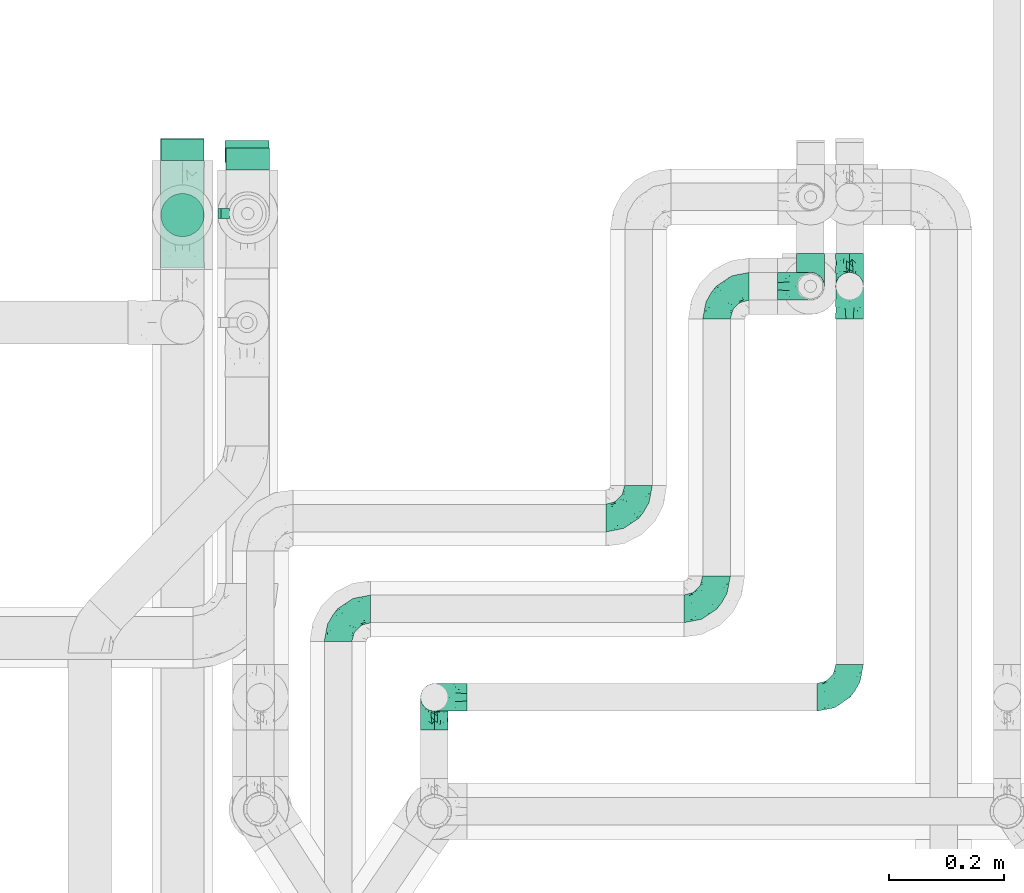
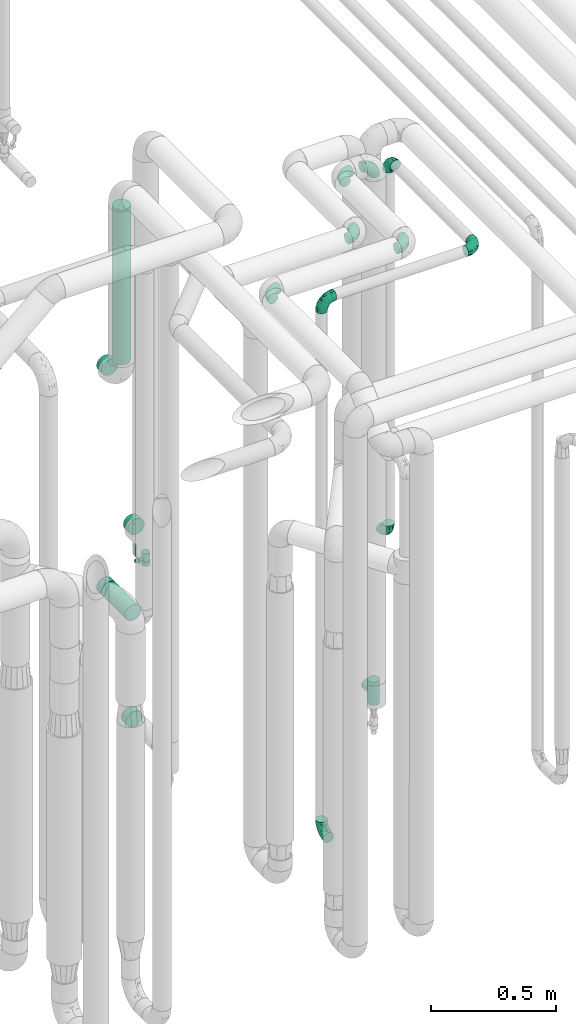
# One storey, part 674 of 827: 15 flow fittings, 2 flow segments, 1 flow controller.
"""IFC2X3 building model written with IfcOpenShell, lengths in millimetres."""

from ifc_helpers import new_model, entity, si_unit, converted_unit, derived_unit, direction, frame, origin, origin_2d_with_axis, place, context, subcontext, project, spatial, polyline, circle, outline, extrude, faceted_brep, source, transform, mapped, material, material_list, type_object, type_shapes, element, save


model = new_model("IFC2X3")

# Units and contexts
model_context = context("Model", 3, precision=0.01, world=origin(), true_north=direction((6.12303176911189e-17, 1.0)))
body_context = subcontext(model_context, "Body", "Model", "MODEL_VIEW")
ifc_project = project(units=[si_unit("LENGTHUNIT", "METRE", prefix="MILLI"), si_unit("AREAUNIT", "SQUARE_METRE"), si_unit("VOLUMEUNIT", "CUBIC_METRE"), converted_unit("PLANEANGLEUNIT", "DEGREE", entity("IfcRatioMeasure", 0.0174532925199433), si_unit("PLANEANGLEUNIT", "RADIAN"), dimensions=[0, 0, 0, 0, 0, 0, 0]), si_unit("MASSUNIT", "GRAM", prefix="KILO"), derived_unit("MASSDENSITYUNIT", [(si_unit("MASSUNIT", "GRAM", prefix="KILO"), 1), (si_unit("LENGTHUNIT", "METRE"), -3)]), derived_unit("MOMENTOFINERTIAUNIT", [(si_unit("LENGTHUNIT", "METRE"), 4)]), si_unit("TIMEUNIT", "SECOND"), si_unit("FREQUENCYUNIT", "HERTZ"), si_unit("THERMODYNAMICTEMPERATUREUNIT", "DEGREE_CELSIUS"), derived_unit("THERMALTRANSMITTANCEUNIT", [(si_unit("MASSUNIT", "GRAM", prefix="KILO"), 1), (si_unit("THERMODYNAMICTEMPERATUREUNIT", "KELVIN"), -1), (si_unit("TIMEUNIT", "SECOND"), -3)]), derived_unit("VOLUMETRICFLOWRATEUNIT", [(si_unit("LENGTHUNIT", "METRE"), 3), (si_unit("TIMEUNIT", "SECOND"), -1)]), derived_unit("MASSFLOWRATEUNIT", [(si_unit("MASSUNIT", "GRAM", prefix="KILO"), 1), (si_unit("TIMEUNIT", "SECOND"), -1)]), derived_unit("ROTATIONALFREQUENCYUNIT", [(si_unit("TIMEUNIT", "SECOND"), -1)]), si_unit("ELECTRICCURRENTUNIT", "AMPERE"), si_unit("ELECTRICVOLTAGEUNIT", "VOLT"), si_unit("POWERUNIT", "WATT"), si_unit("FORCEUNIT", "NEWTON", prefix="KILO"), si_unit("ILLUMINANCEUNIT", "LUX"), si_unit("LUMINOUSFLUXUNIT", "LUMEN"), si_unit("LUMINOUSINTENSITYUNIT", "CANDELA"), derived_unit("USERDEFINED", [(si_unit("MASSUNIT", "GRAM", prefix="KILO"), -1), (si_unit("LENGTHUNIT", "METRE"), -2), (si_unit("TIMEUNIT", "SECOND"), 3), (si_unit("LUMINOUSFLUXUNIT", "LUMEN"), 1)]), derived_unit("LINEARVELOCITYUNIT", [(si_unit("LENGTHUNIT", "METRE"), 1), (si_unit("TIMEUNIT", "SECOND"), -1)]), si_unit("PRESSUREUNIT", "PASCAL"), derived_unit("USERDEFINED", [(si_unit("LENGTHUNIT", "METRE"), -2), (si_unit("MASSUNIT", "GRAM", prefix="KILO"), 1), (si_unit("TIMEUNIT", "SECOND"), -2)]), derived_unit("LINEARFORCEUNIT", [(si_unit("MASSUNIT", "GRAM", prefix="KILO"), 1), (si_unit("LENGTHUNIT", "METRE"), 1), (si_unit("TIMEUNIT", "SECOND"), -2), (si_unit("LENGTHUNIT", "METRE"), -1)]), derived_unit("PLANARFORCEUNIT", [(si_unit("MASSUNIT", "GRAM", prefix="KILO"), 1), (si_unit("LENGTHUNIT", "METRE"), 1), (si_unit("TIMEUNIT", "SECOND"), -2), (si_unit("LENGTHUNIT", "METRE"), -2)])], contexts=[model_context])

# Site, building, storey
site_placement = place(None, origin())
site = spatial("IfcSite", under=ifc_project, at=site_placement, CompositionType="ELEMENT")
building_placement = place(site_placement, origin())
building = spatial("IfcBuilding", under=site, at=building_placement, CompositionType="ELEMENT")
storey_placement = place(building_placement, frame((0.0, 0.0, 28200.0)))
storey = spatial("IfcBuildingStorey", under=building, at=storey_placement, Name="08", CompositionType="ELEMENT", Elevation=28200.0)

# Flow segments
pipe_segment_type = type_object("IfcPipeSegmentType", PredefinedType="NOTDEFINED")
flow_segment_1_placement = place(storey_placement, frame((46517.3, 15183.04, 1125.65)))
element("IfcFlowSegment", 1, at=flow_segment_1_placement, inside=storey, type_object=pipe_segment_type, context=body_context, shape_type="SweptSolid", body=[
    extrude(circle(Radius=37.75, at=origin_2d_with_axis()), frame((39.35, 0.0, 39.35), z_axis=(0.0, 1.0, 0.0), x_axis=(1.0, 0.0, 0.0)), (0.0, 0.0, 1.0), 188.200000000003),
])
flow_segment_2_placement = place(storey_placement, frame((46517.43, 15236.02, 2345.05)))
element("IfcFlowSegment", 2, at=flow_segment_2_placement, inside=storey, type_object=pipe_segment_type, context=body_context, shape_type="SweptSolid", body=[
    extrude(circle(Radius=37.75, at=origin_2d_with_axis()), frame((39.35, 39.35, 0.0)), (0.0, 0.0, 1.0), 760.000000000018),
])

# Flow controller
ifc_material = material()
ifc_material_list = material_list([ifc_material, ifc_material, ifc_material, ifc_material, ifc_material])
valve_type = type_object("IfcValveType", PredefinedType="NOTDEFINED", material=ifc_material_list)
shared_shape_1 = source(origin(), body_context, "Body", "SweptSolid", [
    extrude(circle(Radius=17.5, at=origin_2d_with_axis()), frame((-30.5, 0.0, 0.0), z_axis=(1.0, 0.0, 0.0), x_axis=(0.0, 1.0, 0.0)), (0.0, 0.0, 1.0), 20.3333333333333),
    extrude(circle(Radius=16.0, at=origin_2d_with_axis()), frame((-10.17, 0.0, 0.0), z_axis=(1.0, 0.0, 0.0), x_axis=(0.0, 1.0, 0.0)), (0.0, 0.0, 1.0), 20.3333333333333),
    extrude(circle(Radius=17.5, at=origin_2d_with_axis()), frame((10.17, 0.0, 0.0), z_axis=(1.0, 0.0, 0.0), x_axis=(0.0, 1.0, 0.0)), (0.0, 0.0, 1.0), 20.3333333333333),
    extrude(outline(polyline([(-38.75, -5.0), (-38.75, -10.0), (-17.92, -10.0), (2.08, 5.0), (56.25, 5.0), (56.25, 10.0), (0.42, 10.0), (-19.58, -5.0), (-38.75, -5.0)])), frame((28.75, -8.75, 41.5), z_axis=(0.0, -1.0, 0.0), x_axis=(1.0, 0.0, 0.0)), (0.0, 0.0, -1.0), 17.5),
    extrude(circle(Radius=8.0, at=origin_2d_with_axis()), origin(), (0.0, 0.0, 1.0), 49.0),
])
type_shapes(valve_type, [shared_shape_1])
flow_controller_placement = place(storey_placement, frame((46670.56, 15278.08, 1335.75), z_axis=(-1.0, 0.0, 0.0), x_axis=(0.0, 0.0, 1.0)))
element("IfcFlowController", 3, at=flow_controller_placement, inside=storey, type_object=valve_type, material=ifc_material, context=body_context, shape_type="MappedRepresentation", body=[
    mapped(shared_shape_1, transform((0.0, 0.0, 0.0), scale=1.0)),
])

# Flow fittings
pipe_fitting_type_1 = type_object("IfcPipeFittingType", Name="ADSK_1", PredefinedType="NOTDEFINED", material=ifc_material)
shared_shape_2 = source(origin(), body_context, "Body", "SweptSolid", [
    extrude(circle(Radius=38.05, at=origin_2d_with_axis()), frame((0.0, 0.0, 0.0), z_axis=(1.0, 0.0, 0.0), x_axis=(0.0, 1.0, 0.0)), (0.0, 0.0, 1.0), 38.0000000000003),
])
type_shapes(pipe_fitting_type_1, [shared_shape_2])
for number, where, z_axis, x_axis, name in (
    (4, (46556.77, 15370.36, 2250.05), (1.0, 0.0, 0.0), (0.0, 1.0, 0.0), "ADSK_1"),
    (5, (46670.56, 15354.08, 1442.25), (-1.0, 0.0, 0.0), (0.0, 1.0, 0.0), "ADSK_1"),
    (6, (46556.64, 15371.24, 1165.0), (0.0, 0.0, 1.0), (0.0, 1.0, 0.0), "ADSK_1"),
    (7, (46669.38, 15367.24, 494.0), (0.0, 0.0, 1.0), (0.0, 1.0, 0.0), "ADSK_1"),
):
    element("IfcFlowFitting", number, at=place(storey_placement, frame(where, z_axis=z_axis, x_axis=x_axis)), inside=storey, type_object=pipe_fitting_type_1, material=ifc_material, Name=name, ObjectType="ADSK_1", context=body_context, shape_type="MappedRepresentation", body=[
        mapped(shared_shape_2, transform((0.0, 0.0, 0.0), scale=1.0)),
    ])
pipe_fitting_type_2 = type_object("IfcPipeFittingType", Name="ADSK_1", PredefinedType="NOTDEFINED", material=ifc_material)
shared_shape_3 = source(origin(), body_context, "Body", "Brep", [
    faceted_brep([(-57.0, 12.07, -20.91), (-57.0, 6.25, -23.33), (-57.0, 0.0, -24.15), (-57.0, -6.25, -23.33), (-57.0, -12.08, -20.91), (-57.0, -17.08, -17.08), (-57.0, -20.91, -12.08), (-57.0, -23.33, -6.25), (-57.0, -24.15, 0.0), (-57.0, -23.33, 6.25), (-57.0, -20.91, 12.07), (-57.0, -17.08, 17.08), (-57.0, -12.08, 20.91), (-57.0, -6.25, 23.33), (-57.0, 0.0, 24.15), (-57.0, 6.25, 23.33), (-57.0, 12.07, 20.91), (-57.0, 17.08, 17.08), (-57.0, 20.91, 12.07), (-57.0, 23.33, 6.25), (-57.0, 24.15, 0.0), (-57.0, 23.33, -6.25), (-57.0, 20.91, -12.08), (-57.0, 17.08, -17.08), (0.0, 57.0, -24.15), (-6.25, 57.0, -23.33), (-12.07, 57.0, -20.91), (-17.08, 57.0, -17.08), (-20.91, 57.0, -12.08), (-23.33, 57.0, -6.25), (-24.15, 57.0, 0.0), (-23.33, 57.0, 6.25), (-20.91, 57.0, 12.07), (-17.08, 57.0, 17.08), (-12.07, 57.0, 20.91), (-6.25, 57.0, 23.33), (0.0, 57.0, 24.15), (6.25, 57.0, 23.33), (12.08, 57.0, 20.91), (17.08, 57.0, 17.08), (20.91, 57.0, 12.07), (23.33, 57.0, 6.25), (24.15, 57.0, 0.0), (23.33, 57.0, -6.25), (20.91, 57.0, -12.08), (17.08, 57.0, -17.08), (12.08, 57.0, -20.91), (6.25, 57.0, -23.33), (14.9, 21.14, 6.17), (13.61, 24.64, 12.48), (6.23, 8.95, 8.98), (-41.47, -21.06, 0.0), (-41.92, -18.38, 13.72), (-24.64, -13.61, 12.48), (-37.37, -13.24, 18.15), (-6.8, -4.93, 8.18), (-21.76, -15.19, 6.22), (-12.78, -9.18, 0.0), (-37.73, -20.51, 7.75), (-7.38, 7.38, 20.24), (-23.37, -4.26, 20.42), (-11.9, -3.19, 15.86), (-42.14, -8.7, 21.82), (13.24, 37.37, 18.15), (9.33, 23.53, 16.85), (4.26, 23.37, 20.42), (2.77, 10.92, 15.55), (-29.46, 0.91, 23.52), (-44.13, 20.56, 15.69), (-39.25, 26.33, 10.88), (-49.02, 22.92, 9.96), (-34.58, 23.87, 17.15), (-15.8, 6.8, 22.81), (-8.67, 20.47, 23.88), (-18.12, 12.9, 24.08), (-48.29, 14.92, 19.65), (-44.06, -2.85, 23.78), (-9.23, 48.95, 22.58), (-3.78, 42.74, 24.07), (-40.34, 4.26, 24.09), (-44.02, 26.14, 5.46), (-44.04, 9.88, 22.74), (-4.95, 16.87, 22.52), (-2.75, 1.43, 12.5), (-25.48, 40.98, 10.71), (20.51, 37.73, 7.75), (18.38, 41.92, 13.72), (8.7, 42.14, 21.82), (-25.95, -17.97, 0.0), (2.85, 44.06, 23.78), (21.06, 41.47, 0.0), (17.97, 25.95, 0.0), (-24.04, -9.27, 17.13), (-33.26, 33.26, 5.86), (-28.55, 40.57, 0.0), (-40.57, 28.55, 0.0), (-25.29, 47.19, 4.06), (-27.01, 31.1, 16.77), (-15.7, 43.95, 19.9), (-20.27, 45.22, 15.61), (-30.53, 31.98, 12.64), (-11.28, 38.33, 22.92), (-9.97, 27.88, 24.09), (-20.15, 30.26, 21.25), (-31.25, 11.75, 23.64), (-28.75, 7.23, 24.15), (-29.53, 18.06, 22.27), (-28.44, 24.21, 20.02), (-37.55, 17.7, 20.26), (-15.88, 29.25, 22.99), (-20.82, 20.82, 23.44), (-0.91, 29.46, 23.52), (-13.5, -7.67, 12.04), (1.49, 1.56, 5.16), (8.86, 10.35, 4.59), (0.38, -0.38, 0.0), (9.18, 12.78, 0.0), (-37.37, -13.24, -18.15), (8.86, 10.35, -4.59), (-45.22, 20.27, -15.61), (-43.95, 15.7, -19.9), (-38.33, 11.28, -22.92), (-48.95, 9.23, -22.58), (-47.19, 25.29, -4.06), (-33.26, 33.26, -5.86), (18.38, 41.92, -13.72), (-30.26, 20.15, -21.25), (2.85, 44.06, -23.78), (-4.26, 40.34, -24.09), (-40.98, 25.48, -10.71), (-41.92, -18.38, -13.72), (9.25, 23.5, -16.92), (4.26, 23.37, -20.42), (13.24, 37.37, -18.15), (-37.73, -20.51, -7.75), (-11.75, 31.25, -23.64), (-7.23, 28.75, -24.15), (-12.9, 18.12, -24.08), (8.7, 42.14, -21.82), (-44.06, -2.85, -23.78), (-6.8, 15.8, -22.81), (-20.47, 8.67, -23.88), (-24.64, -13.61, -12.48), (-42.74, 3.78, -24.07), (-18.06, 29.53, -22.27), (-24.21, 28.44, -20.02), (-27.88, 9.97, -24.09), (-31.1, 27.01, -16.77), (-26.14, 44.02, -5.46), (14.9, 21.14, -6.17), (20.51, 37.73, -7.75), (-9.88, 44.04, -22.74), (-20.56, 44.13, -15.69), (-21.76, -15.19, -6.22), (-13.5, -7.67, -12.04), (-24.14, -9.76, -16.74), (-11.9, -3.19, -15.86), (-14.92, 48.29, -19.65), (-23.37, -4.26, -20.42), (-0.91, 29.46, -23.52), (-26.33, 39.25, -10.88), (-23.87, 34.58, -17.15), (-42.14, -8.7, -21.82), (-22.92, 49.02, -9.96), (13.61, 24.64, -12.48), (-31.98, 30.53, -12.64), (-16.87, 4.95, -22.52), (-17.7, 37.55, -20.26), (-29.25, 15.88, -22.99), (-20.82, 20.82, -23.44), (-29.46, 0.91, -23.52), (-7.38, 7.38, -20.24), (2.77, 10.92, -15.55), (6.23, 8.95, -8.98), (-6.8, -4.93, -8.18), (-2.81, 1.41, -12.54), (1.49, 1.56, -5.16)], [[[0, 1, 2, 3, 4, 5, 6, 7, 8, 9, 10, 11, 12, 13, 14, 15, 16, 17, 18, 19, 20, 21, 22, 23]], [[24, 25, 26, 27, 28, 29, 30, 31, 32, 33, 34, 35, 36, 37, 38, 39, 40, 41, 42, 43, 44, 45, 46, 47]], [[48, 49, 50]], [[9, 8, 51]], [[52, 53, 54]], [[55, 56, 57]], [[10, 58, 52]], [[9, 58, 10]], [[59, 60, 61]], [[54, 12, 11]], [[54, 62, 12]], [[63, 39, 38]], [[64, 65, 66]], [[62, 60, 67]], [[68, 69, 70]], [[71, 69, 68]], [[72, 73, 74]], [[16, 75, 17]], [[13, 76, 14]], [[35, 77, 78]], [[14, 79, 15]], [[17, 68, 18]], [[14, 76, 79]], [[20, 19, 80]], [[70, 19, 18]], [[81, 15, 79]], [[15, 81, 16]], [[73, 72, 82]], [[66, 83, 50]], [[32, 31, 84]], [[85, 86, 49]], [[63, 87, 65]], [[56, 58, 88]], [[36, 89, 37]], [[85, 41, 40]], [[36, 35, 78]], [[90, 41, 85]], [[40, 39, 86]], [[12, 62, 13]], [[86, 85, 40]], [[48, 85, 49]], [[85, 91, 90]], [[87, 38, 37]], [[92, 60, 54]], [[80, 69, 93]], [[93, 94, 95]], [[10, 52, 11]], [[94, 96, 30]], [[97, 98, 99]], [[80, 93, 95]], [[100, 97, 84]], [[99, 98, 33]], [[101, 102, 78]], [[103, 101, 98]], [[96, 31, 30]], [[77, 98, 101]], [[77, 35, 34]], [[34, 33, 98]], [[9, 51, 58]], [[87, 63, 38]], [[104, 105, 74]], [[106, 103, 107]], [[106, 81, 104]], [[75, 68, 17]], [[108, 107, 71]], [[33, 32, 99]], [[109, 103, 110]], [[101, 109, 102]], [[89, 78, 111]], [[53, 52, 58]], [[54, 11, 52]], [[60, 62, 54]], [[88, 58, 51]], [[76, 62, 67]], [[53, 112, 92]], [[60, 59, 72]], [[39, 63, 86]], [[49, 86, 63]], [[89, 87, 37]], [[42, 41, 90]], [[111, 82, 65]], [[111, 65, 87]], [[65, 59, 66]], [[104, 81, 79]], [[75, 81, 108]], [[32, 84, 99]], [[97, 99, 84]], [[98, 97, 103]], [[106, 107, 108]], [[74, 102, 110]], [[111, 78, 102]], [[74, 110, 104]], [[74, 67, 72]], [[61, 92, 112]], [[66, 59, 61]], [[56, 53, 58]], [[66, 50, 49]], [[61, 112, 83]], [[66, 49, 64]], [[78, 89, 36]], [[87, 89, 111]], [[62, 76, 13]], [[79, 76, 67]], [[100, 93, 69]], [[96, 93, 84]], [[55, 113, 50]], [[113, 114, 50]], [[104, 79, 105]], [[106, 104, 110]], [[20, 80, 95]], [[85, 48, 91]], [[115, 114, 113]], [[116, 91, 48]], [[70, 80, 19]], [[93, 96, 94]], [[84, 31, 96]], [[103, 106, 110]], [[81, 106, 108]], [[103, 97, 107]], [[71, 107, 97]], [[71, 97, 100]], [[108, 71, 68]], [[79, 67, 105]], [[67, 74, 105]], [[115, 113, 57]], [[112, 56, 55]], [[56, 88, 57]], [[60, 72, 67]], [[82, 72, 59]], [[65, 82, 59]], [[82, 111, 73]], [[111, 102, 73]], [[102, 74, 73]], [[81, 75, 16]], [[68, 75, 108]], [[68, 70, 18]], [[80, 70, 69]], [[98, 77, 34]], [[78, 77, 101]], [[93, 100, 84]], [[71, 100, 69]], [[102, 109, 110]], [[101, 103, 109]], [[53, 92, 54]], [[61, 60, 92]], [[56, 112, 53]], [[83, 112, 55]], [[50, 83, 55]], [[61, 83, 66]], [[49, 63, 64]], [[65, 64, 63]], [[57, 113, 55]], [[114, 115, 116]], [[116, 48, 114]], [[48, 50, 114]], [[117, 5, 4]], [[116, 115, 118]], [[119, 120, 23]], [[121, 122, 120]], [[95, 123, 20]], [[0, 23, 120]], [[124, 95, 94]], [[125, 45, 44]], [[121, 120, 126]], [[24, 127, 128]], [[22, 21, 129]], [[0, 122, 1]], [[5, 117, 130]], [[131, 132, 133]], [[134, 88, 51]], [[135, 136, 137]], [[6, 5, 130]], [[46, 138, 47]], [[139, 3, 2]], [[140, 141, 137]], [[6, 134, 7]], [[134, 130, 142]], [[143, 2, 1]], [[144, 126, 145]], [[121, 146, 143]], [[147, 120, 119]], [[94, 148, 124]], [[149, 150, 91]], [[30, 29, 148]], [[151, 25, 128]], [[27, 152, 28]], [[134, 153, 88]], [[154, 155, 156]], [[27, 26, 157]], [[151, 26, 25]], [[155, 158, 156]], [[24, 47, 127]], [[1, 122, 143]], [[138, 132, 159]], [[160, 152, 161]], [[24, 128, 25]], [[46, 133, 138]], [[162, 117, 4]], [[148, 160, 124]], [[152, 160, 163]], [[154, 142, 155]], [[45, 125, 133]], [[133, 46, 45]], [[125, 164, 133]], [[51, 7, 134]], [[42, 90, 43]], [[165, 147, 129]], [[153, 134, 142]], [[43, 150, 44]], [[162, 4, 3]], [[141, 140, 166]], [[117, 162, 158]], [[163, 29, 28]], [[43, 90, 150]], [[123, 21, 20]], [[144, 151, 135]], [[157, 152, 27]], [[167, 145, 161]], [[23, 22, 119]], [[168, 126, 169]], [[121, 168, 146]], [[139, 143, 170]], [[142, 130, 117]], [[8, 7, 51]], [[134, 6, 130]], [[139, 162, 3]], [[170, 166, 158]], [[170, 158, 162]], [[158, 171, 156]], [[44, 150, 125]], [[91, 150, 90]], [[164, 125, 150]], [[132, 138, 133]], [[127, 138, 159]], [[131, 164, 172]], [[132, 171, 140]], [[135, 151, 128]], [[157, 151, 167]], [[22, 129, 119]], [[147, 119, 129]], [[120, 147, 126]], [[144, 145, 167]], [[137, 146, 169]], [[170, 143, 146]], [[137, 169, 135]], [[137, 159, 140]], [[171, 172, 156]], [[173, 174, 175]], [[156, 175, 154]], [[174, 57, 153]], [[132, 172, 171]], [[172, 164, 173]], [[143, 139, 2]], [[162, 139, 170]], [[138, 127, 47]], [[128, 127, 159]], [[165, 124, 160]], [[123, 124, 129]], [[149, 173, 164]], [[176, 174, 173]], [[135, 128, 136]], [[144, 135, 169]], [[150, 149, 164]], [[176, 118, 115]], [[149, 91, 116]], [[30, 148, 94]], [[163, 148, 29]], [[124, 123, 95]], [[129, 21, 123]], [[126, 144, 169]], [[151, 144, 167]], [[126, 147, 145]], [[161, 145, 147]], [[161, 147, 165]], [[167, 161, 152]], [[128, 159, 136]], [[159, 137, 136]], [[154, 153, 142]], [[132, 140, 159]], [[174, 176, 57]], [[57, 88, 153]], [[166, 140, 171]], [[158, 166, 171]], [[166, 170, 141]], [[170, 146, 141]], [[146, 137, 141]], [[151, 157, 26]], [[152, 157, 167]], [[152, 163, 28]], [[148, 163, 160]], [[120, 122, 0]], [[143, 122, 121]], [[124, 165, 129]], [[161, 165, 160]], [[146, 168, 169]], [[121, 126, 168]], [[142, 117, 155]], [[158, 155, 117]], [[175, 156, 172]], [[153, 154, 174]], [[173, 175, 172]], [[174, 154, 175]], [[164, 131, 133]], [[172, 132, 131]], [[176, 173, 118]], [[57, 176, 115]], [[173, 149, 118]], [[149, 116, 118]]]),
])
type_shapes(pipe_fitting_type_2, [shared_shape_3])
for number, where, z_axis, x_axis, name in (
    (8, (46996.03, 14434.53, 400.0), (-1.0, 0.0, 0.0), (0.0, 0.0, -1.0), "ADSK_1"),
    (9, (47720.02, 15151.24, 3000.0), (-1.0, 0.0, 0.0), (0.0, 1.0, 0.0), "ADSK_1"),
    (10, (47720.02, 15151.24, 1160.0), (1.0, 0.0, 0.0), (0.0, 0.0, -1.0), "ADSK_1"),
    (11, (47488.0, 15151.24, 3000.0), (0.0, 0.0, 1.0), (-1.0, 0.0, 0.0), "ADSK_1"),
    (12, (47651.75, 15151.24, 3000.0), (0.0, 1.0, 0.0), (1.0, 0.0, 0.0), "ADSK_1"),
):
    element("IfcFlowFitting", number, at=place(storey_placement, frame(where, z_axis=z_axis, x_axis=x_axis)), inside=storey, type_object=pipe_fitting_type_2, material=ifc_material, Name=name, ObjectType="ADSK_1", context=body_context, shape_type="MappedRepresentation", body=[
        mapped(shared_shape_3, transform((0.0, 0.0, 0.0), scale=1.0)),
    ])
flow_fitting_1_placement = place(storey_placement, frame((47720.02, 14434.53, 3000.0)))
element("IfcFlowFitting", 13, at=flow_fitting_1_placement, inside=storey, type_object=pipe_fitting_type_2, material=ifc_material, Name="ADSK_1", ObjectType="ADSK_1", context=body_context, shape_type="MappedRepresentation", body=[
    mapped(shared_shape_3, transform((0.0, 0.0, 0.0), scale=1.0)),
])
flow_fitting_2_placement = place(storey_placement, frame((46996.03, 14434.53, 3000.0), z_axis=(0.0, 1.0, 0.0), x_axis=(0.0, 0.0, 1.0)))
element("IfcFlowFitting", 14, at=flow_fitting_2_placement, inside=storey, type_object=pipe_fitting_type_2, material=ifc_material, Name="ADSK_1", ObjectType="ADSK_1", context=body_context, shape_type="MappedRepresentation", body=[
    mapped(shared_shape_3, transform((0.0, 0.0, 0.0), scale=1.0)),
])
flow_fitting_3_placement = place(storey_placement, frame((47488.0, 14588.75, 3000.0)))
element("IfcFlowFitting", 15, at=flow_fitting_3_placement, inside=storey, type_object=pipe_fitting_type_2, material=ifc_material, Name="ADSK_1", ObjectType="ADSK_1", context=body_context, shape_type="MappedRepresentation", body=[
    mapped(shared_shape_3, transform((0.0, 0.0, 0.0), scale=1.0)),
])
flow_fitting_4_placement = place(storey_placement, frame((46828.0, 14588.75, 3000.0), z_axis=(0.0, 0.0, 1.0), x_axis=(-1.0, 0.0, 0.0)))
element("IfcFlowFitting", 16, at=flow_fitting_4_placement, inside=storey, type_object=pipe_fitting_type_2, material=ifc_material, Name="ADSK_1", ObjectType="ADSK_1", context=body_context, shape_type="MappedRepresentation", body=[
    mapped(shared_shape_3, transform((0.0, 0.0, 0.0), scale=1.0)),
])
flow_fitting_5_placement = place(storey_placement, frame((47352.0, 14747.03, 3000.0)))
element("IfcFlowFitting", 17, at=flow_fitting_5_placement, inside=storey, type_object=pipe_fitting_type_2, material=ifc_material, Name="ADSK_1", ObjectType="ADSK_1", context=body_context, shape_type="MappedRepresentation", body=[
    mapped(shared_shape_3, transform((0.0, 0.0, 0.0), scale=1.0)),
])
pipe_fitting_type_3 = type_object("IfcPipeFittingType", Name="ADSK_1", PredefinedType="NOTDEFINED", material=ifc_material)
shared_shape_4 = source(origin(), body_context, "Body", "Brep", [
    faceted_brep([(-57.0, 12.07, -20.91), (-57.0, 6.25, -23.33), (-57.0, 0.0, -24.15), (-57.0, -6.25, -23.33), (-57.0, -12.08, -20.91), (-57.0, -17.08, -17.08), (-57.0, -20.91, -12.08), (-57.0, -23.33, -6.25), (-57.0, -24.15, 0.0), (-57.0, -23.33, 6.25), (-57.0, -20.91, 12.07), (-57.0, -17.08, 17.08), (-57.0, -12.08, 20.91), (-57.0, -6.25, 23.33), (-57.0, 0.0, 24.15), (-57.0, 6.25, 23.33), (-57.0, 12.07, 20.91), (-57.0, 17.08, 17.08), (-57.0, 20.91, 12.07), (-57.0, 23.33, 6.25), (-57.0, 24.15, 0.0), (-57.0, 23.33, -6.25), (-57.0, 20.91, -12.08), (-57.0, 17.08, -17.08), (57.0, 0.0, -24.15), (57.0, 6.25, -23.33), (57.0, 12.07, -20.91), (57.0, 17.08, -17.08), (57.0, 20.91, -12.08), (57.0, 23.33, -6.25), (57.0, 24.15, 0.0), (57.0, 23.33, 6.25), (57.0, 20.91, 12.07), (57.0, 17.08, 17.08), (57.0, 12.07, 20.91), (57.0, 6.25, 23.33), (57.0, 0.0, 24.15), (57.0, -6.25, 23.33), (57.0, -12.08, 20.91), (57.0, -17.08, 17.08), (57.0, -20.91, 12.07), (57.0, -23.33, 6.25), (57.0, -24.15, 0.0), (57.0, -23.33, -6.25), (57.0, -20.91, -12.08), (57.0, -17.08, -17.08), (57.0, -12.08, -20.91), (57.0, -6.25, -23.33), (23.27, -23.27, 6.45), (24.15, -24.15, 0.0), (-24.15, -24.15, 0.0), (20.9, -20.9, 12.1), (13.54, -13.54, 20.0), (17.52, -17.52, 16.62), (-23.27, -23.27, 6.45), (-20.9, -20.9, 12.1), (-17.52, -17.52, 16.62), (-13.54, -13.54, 20.0), (-9.19, -9.19, 22.33), (9.19, -9.19, 22.33), (4.64, -4.64, 23.7), (0.0, 0.0, 24.15), (-4.64, -4.64, 23.7), (4.64, -4.64, -23.7), (0.0, 0.0, -24.15), (-4.64, -4.64, -23.7), (-9.19, -9.19, -22.33), (9.19, -9.19, -22.33), (13.54, -13.54, -20.0), (17.52, -17.52, -16.62), (20.9, -20.9, -12.1), (23.27, -23.27, -6.45), (-13.54, -13.54, -20.0), (-17.52, -17.52, -16.62), (-23.27, -23.27, -6.45), (-20.9, -20.9, -12.1), (0.0, -57.0, -24.15), (6.25, -57.0, -23.33), (12.08, -57.0, -20.91), (17.08, -57.0, -17.08), (20.91, -57.0, -12.08), (23.33, -57.0, -6.25), (24.15, -57.0, 0.0), (23.33, -57.0, 6.25), (20.91, -57.0, 12.07), (17.08, -57.0, 17.08), (12.08, -57.0, 20.91), (6.25, -57.0, 23.33), (0.0, -57.0, 24.15), (-6.25, -57.0, 23.33), (-12.07, -57.0, 20.91), (-17.08, -57.0, 17.08), (-20.91, -57.0, 12.07), (-23.33, -57.0, 6.25), (-24.15, -57.0, 0.0), (-23.33, -57.0, -6.25), (-20.91, -57.0, -12.08), (-17.08, -57.0, -17.08), (-12.07, -57.0, -20.91), (-6.25, -57.0, -23.33)], [[[0, 1, 2, 3, 4, 5, 6, 7, 8, 9, 10, 11, 12, 13, 14, 15, 16, 17, 18, 19, 20, 21, 22, 23]], [[24, 25, 26, 27, 28, 29, 30, 31, 32, 33, 34, 35, 36, 37, 38, 39, 40, 41, 42, 43, 44, 45, 46, 47]], [[41, 40, 48]], [[42, 41, 49]], [[50, 9, 8]], [[49, 41, 48]], [[40, 51, 48]], [[39, 38, 52]], [[51, 40, 53]], [[52, 53, 39]], [[53, 40, 39]], [[50, 54, 9]], [[9, 54, 10]], [[54, 55, 10]], [[56, 57, 11]], [[11, 10, 56]], [[11, 57, 12]], [[56, 10, 55]], [[12, 57, 58]], [[52, 38, 59]], [[60, 36, 61]], [[62, 61, 14]], [[59, 37, 60]], [[37, 59, 38]], [[60, 37, 36]], [[61, 36, 35, 15, 14]], [[32, 31, 19, 18]], [[17, 16, 34, 33]], [[18, 17, 33, 32]], [[35, 34, 16, 15]], [[20, 19, 31, 30]], [[62, 13, 58]], [[13, 62, 14]], [[58, 13, 12]], [[27, 23, 22, 28]], [[22, 21, 29, 28]], [[0, 23, 27, 26]], [[20, 30, 29, 21]], [[24, 47, 63]], [[24, 64, 2, 1, 25]], [[64, 24, 63]], [[2, 64, 65]], [[26, 25, 1, 0]], [[65, 66, 3]], [[2, 65, 3]], [[66, 4, 3]], [[63, 47, 67]], [[46, 45, 68]], [[69, 68, 45]], [[44, 70, 69]], [[69, 45, 44]], [[46, 68, 67]], [[43, 42, 49]], [[7, 50, 8]], [[43, 71, 44]], [[71, 43, 49]], [[44, 71, 70]], [[72, 4, 66]], [[72, 5, 4]], [[5, 72, 73]], [[5, 73, 6]], [[74, 50, 7]], [[75, 74, 6]], [[74, 7, 6]], [[75, 6, 73]], [[46, 67, 47]], [[76, 77, 78, 79, 80, 81, 82, 83, 84, 85, 86, 87, 88, 89, 90, 91, 92, 93, 94, 95, 96, 97, 98, 99]], [[50, 94, 93]], [[54, 50, 93]], [[91, 90, 57]], [[56, 92, 91]], [[54, 93, 92]], [[58, 90, 89]], [[55, 54, 92]], [[56, 55, 92]], [[58, 57, 90]], [[88, 61, 62]], [[58, 89, 62]], [[56, 91, 57]], [[62, 89, 88]], [[60, 88, 87]], [[86, 59, 87]], [[84, 83, 48]], [[53, 85, 84]], [[52, 86, 85]], [[49, 83, 82]], [[59, 60, 87]], [[52, 59, 86]], [[49, 48, 83]], [[51, 53, 84]], [[48, 51, 84]], [[52, 85, 53]], [[88, 60, 61]], [[82, 81, 49]], [[71, 49, 81]], [[69, 80, 79]], [[79, 78, 68]], [[71, 81, 80]], [[67, 78, 77]], [[70, 71, 80]], [[69, 70, 80]], [[67, 68, 78]], [[76, 64, 63]], [[67, 77, 63]], [[69, 79, 68]], [[63, 77, 76]], [[65, 76, 99]], [[98, 66, 99]], [[96, 95, 74]], [[73, 97, 96]], [[72, 98, 97]], [[50, 95, 94]], [[66, 65, 99]], [[72, 66, 98]], [[50, 74, 95]], [[75, 73, 96]], [[74, 75, 96]], [[72, 97, 73]], [[76, 65, 64]]]),
])
type_shapes(pipe_fitting_type_3, [shared_shape_4])
flow_fitting_6_placement = place(storey_placement, frame((47651.75, 15151.24, 420.25), z_axis=(-1.0, 0.0, 0.0), x_axis=(0.0, 0.0, -1.0)))
element("IfcFlowFitting", 18, at=flow_fitting_6_placement, inside=storey, type_object=pipe_fitting_type_3, material=ifc_material, Name="ADSK_1", ObjectType="ADSK_1", context=body_context, shape_type="MappedRepresentation", body=[
    mapped(shared_shape_4, transform((0.0, 0.0, 0.0), scale=1.0)),
])

save(model, "model.ifc")
